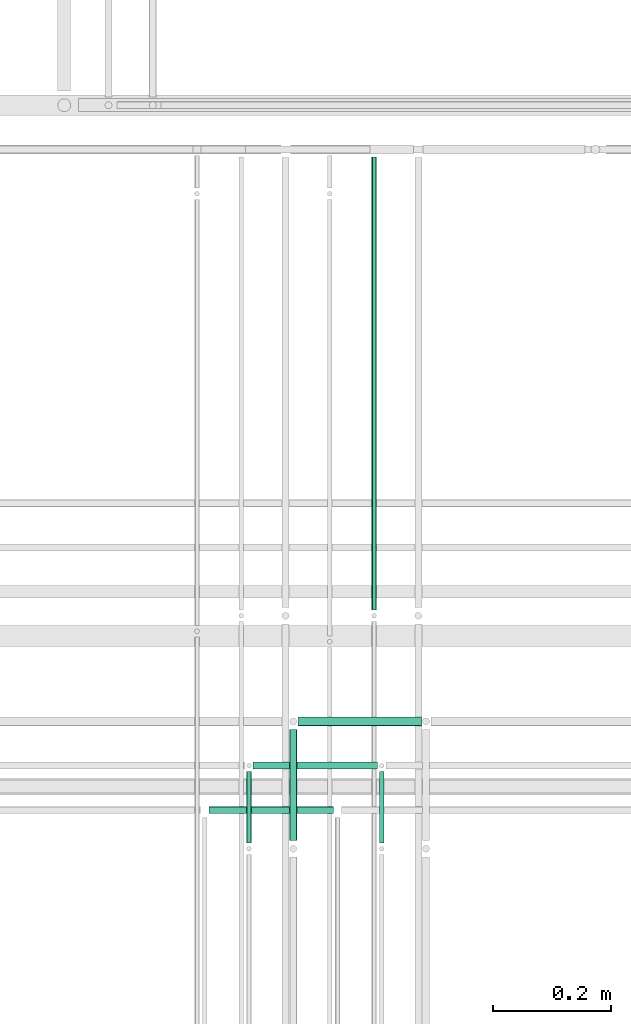
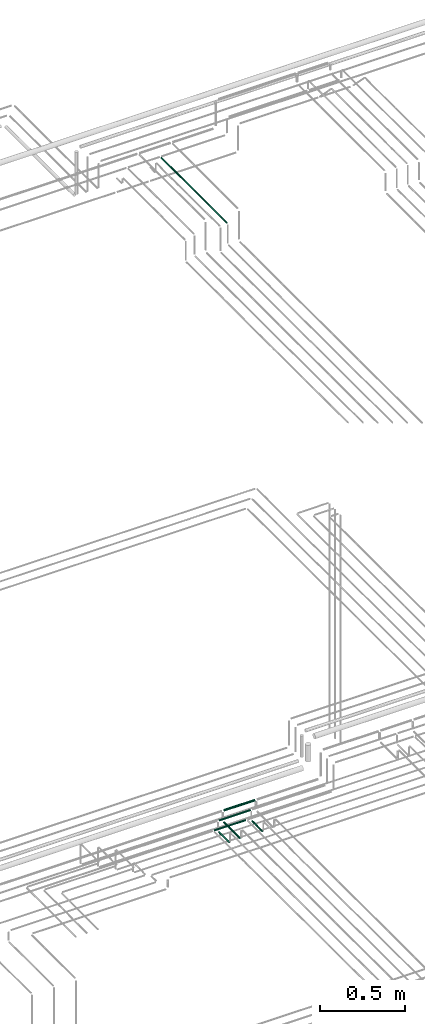
# One storey, part 150 of 331: 7 flow segments.
"""IFC2X3 building model written with IfcOpenShell, lengths in millimetres."""

import ifcopenshell
import ifcopenshell.guid

model = None  # the IFC model being written
_history = None  # IfcOwnerHistory: only IFC2X3 demands one
_inside = {}  # id of a spatial element -> (the spatial element, [elements in it])
_under = {}  # id of a project, library or spatial element -> (it, [spatial elements below it])
_declared = {}  # id of a project -> (the project, [libraries it declares])
_typed = {}  # id of a type object -> (the type object, [elements of that type])
_made_of = {}  # id of a material, layer set ... -> (it, [elements and type objects made of it])


def new_model(schema):
    """Start an empty IFC model of exactly this schema.

    Asked for "IFC4X3", IfcOpenShell would pick the latest addendum, in which some entities
    have other attributes; the version numbers below select the first issue.
    IFC2X3 requires an IfcOwnerHistory on every rooted entity: one is made here for all.
    """
    global model, _history
    if schema == "IFC4X3":
        model = ifcopenshell.file(schema_version=(4, 3, 0, 0))
    else:
        model = ifcopenshell.file(schema=schema)
    _inside.clear()
    _under.clear()
    _declared.clear()
    _typed.clear()
    _made_of.clear()
    _history = None
    if model.schema == "IFC2X3":
        org = make("IfcOrganization", Name="unknown")
        user = make(
            "IfcPersonAndOrganization",
            ThePerson=make("IfcPerson", FamilyName="unknown"),
            TheOrganization=org,
        )
        app = make(
            "IfcApplication",
            ApplicationDeveloper=org,
            Version="unknown",
            ApplicationFullName="unknown",
            ApplicationIdentifier="unknown",
        )
        _history = make(
            "IfcOwnerHistory",
            OwningUser=user,
            OwningApplication=app,
            ChangeAction="ADDED",
            CreationDate=0,
        )
    return model


def make(cls, **values):
    """One entity of the class cls with the attributes given. An attribute that is None is left unset."""
    return model.create_entity(
        cls, **{name: value for name, value in values.items() if value is not None}
    )


def entity(cls, *values):
    """Any entity or typed value of the class cls, its attributes in the order of the schema. None: left unset."""
    e = model.create_entity(cls)
    for i, value in enumerate(values):
        if value is not None:
            e[i] = value
    return e


def rooted(cls, **values):
    """An entity with a GlobalId (a new one), such as an element, a storey or a relation."""
    return make(cls, GlobalId=ifcopenshell.guid.new(), OwnerHistory=_history, **values)


def si_unit(unit_type, name, prefix=None):
    """IfcSIUnit, for example si_unit("LENGTHUNIT", "METRE", prefix="MILLI")."""
    return make("IfcSIUnit", UnitType=unit_type, Prefix=prefix, Name=name)


def converted_unit(unit_type, name, factor, base, dimensions=None, offset=None):
    """IfcConversionBasedUnit, such as the inch: factor (a typed value) times the base unit."""
    return make(
        "IfcConversionBasedUnit"
        if offset is None
        else "IfcConversionBasedUnitWithOffset",
        ConversionOffset=offset,
        Dimensions=None
        if dimensions is None
        else entity("IfcDimensionalExponents", *dimensions),
        UnitType=unit_type,
        Name=name,
        ConversionFactor=make(
            "IfcMeasureWithUnit", ValueComponent=factor, UnitComponent=base
        ),
    )


def derived_unit(unit_type, elements):
    """IfcDerivedUnit: a product of units, each with its exponent."""
    return make(
        "IfcDerivedUnit",
        Elements=[
            make("IfcDerivedUnitElement", Unit=unit, Exponent=power)
            for unit, power in elements
        ],
        UnitType=unit_type,
    )


def assignment(units):
    """IfcUnitAssignment: the units of a project."""
    return None if units is None else make("IfcUnitAssignment", Units=units)


def point(xyz):
    """IfcCartesianPoint."""
    return None if xyz is None else make("IfcCartesianPoint", Coordinates=xyz)


def direction(xyz):
    """IfcDirection."""
    return None if xyz is None else make("IfcDirection", DirectionRatios=xyz)


def frame(location, z_axis=None, x_axis=None):
    """IfcAxis2Placement3D, a coordinate frame: its origin and axes. An axis left out is left unset."""
    return make(
        "IfcAxis2Placement3D",
        Location=point(location),
        Axis=direction(z_axis),
        RefDirection=direction(x_axis),
    )


def frame_2d(location, x_axis=None):
    """IfcAxis2Placement2D, a coordinate frame in the plane: its origin and x axis."""
    return make(
        "IfcAxis2Placement2D", Location=point(location), RefDirection=direction(x_axis)
    )


def origin():
    """The frame at (0, 0, 0) with its axes left unset."""
    return frame((0.0, 0.0, 0.0))


def origin_2d_with_axis():
    """The frame at (0, 0) in the plane with the x axis (1, 0) written out."""
    return frame_2d((0.0, 0.0), x_axis=(1.0, 0.0))


def place(relative_to, where):
    """IfcLocalPlacement: puts the frame where relative to a parent placement (None: the world)."""
    return make(
        "IfcLocalPlacement", PlacementRelTo=relative_to, RelativePlacement=where
    )


def context(
    kind, dimensions, precision=None, world=None, true_north=None, identifier=None
):
    """IfcGeometricRepresentationContext, for example the 3D "Model" context."""
    return make(
        "IfcGeometricRepresentationContext",
        ContextIdentifier=identifier,
        ContextType=kind,
        CoordinateSpaceDimension=dimensions,
        Precision=precision,
        WorldCoordinateSystem=world,
        TrueNorth=true_north,
    )


def subcontext(parent, identifier, kind, view, scale=None):
    """IfcGeometricRepresentationSubContext, for example "Body" below "Model"."""
    return make(
        "IfcGeometricRepresentationSubContext",
        ContextIdentifier=identifier,
        ContextType=kind,
        ParentContext=parent,
        TargetScale=scale,
        TargetView=view,
    )


def project(units=None, contexts=None):
    """IfcProject with its units and contexts."""
    return rooted(
        "IfcProject",
        Name="project",
        RepresentationContexts=contexts,
        UnitsInContext=assignment(units),
    )


def spatial(cls, under=None, at=None, **own):
    """A site, building, storey or space (cls), placed at a placement, below another one or the project."""
    s = rooted(cls, ObjectPlacement=at, **own)
    if under is not None:
        _under.setdefault(under.id(), (under, []))[1].append(s)
    return s


def profile(cls, at=None, kind="AREA", **sizes):
    """A parametric profile (cls). Its sizes go by their IFC names, for example OverallWidth=200.0."""
    return make(cls, ProfileType=kind, Position=at, **sizes)


def circle(**sizes):
    """IfcCircleProfileDef."""
    return profile("IfcCircleProfileDef", **sizes)


def extrude(swept, where, along, depth):
    """IfcExtrudedAreaSolid: the profile swept, set in the frame where, extruded along a direction by depth."""
    return make(
        "IfcExtrudedAreaSolid",
        SweptArea=swept,
        Position=where,
        ExtrudedDirection=direction(along),
        Depth=depth,
    )


def shape(context_of_items, identifier, shape_type, items):
    """IfcShapeRepresentation: the items that make up one representation, for example the "Body"."""
    return make(
        "IfcShapeRepresentation",
        ContextOfItems=context_of_items,
        RepresentationIdentifier=identifier,
        RepresentationType=shape_type,
        Items=items,
    )


def made_of(thing, what):
    """Note that an element or type object is made of a material, layer set ...; save() writes the relation."""
    if what is not None:
        _made_of.setdefault(what.id(), (what, []))[1].append(thing)
    return thing


def type_object(cls, material=None, **own):
    """A type object (cls), such as IfcWallType, which elements share."""
    return made_of(rooted(cls, **own), material)


def element(
    cls,
    number,
    at=None,
    inside=None,
    cuts=None,
    type_object=None,
    material=None,
    context=None,
    identifier="Body",
    shape_type=None,
    held_by="IfcProductDefinitionShape",
    body=None,
    shapes=None,
    **own,
):
    """One element of the class cls, such as IfcWall. Its Tag is "e" and its number.

    at: its placement. inside: the storey or other place that contains it. cuts: it is an
    opening in that element (IfcRelVoidsElement). A single representation is given by context,
    identifier, shape_type and body (its items); several are given by shapes. held_by: the class
    of the entity that holds the representations. save() writes the other relations.
    """
    e = rooted(cls, Tag="e%d" % number, ObjectPlacement=at, **own)
    if body is not None:
        shapes = [shape(context, identifier, shape_type, body)]
    if shapes is not None:
        e.Representation = make(held_by, Representations=shapes)
    if inside is not None:
        _inside.setdefault(inside.id(), (inside, []))[1].append(e)
    if cuts is not None:
        rooted(
            "IfcRelVoidsElement", RelatingBuildingElement=cuts, RelatedOpeningElement=e
        )
    if type_object is not None:
        _typed.setdefault(type_object.id(), (type_object, []))[1].append(e)
    return made_of(e, material)


def aggregate(whole, parts):
    """IfcRelAggregates: a whole, such as a stair, and the parts it consists of."""
    return rooted("IfcRelAggregates", RelatingObject=whole, RelatedObjects=parts)


def save(model, path):
    """Write the relations noted so far, then the file.

    IfcRelAggregates (storeys below a building ...), IfcRelContainedInSpatialStructure (elements
    in a storey), IfcRelDefinesByType, IfcRelAssociatesMaterial and IfcRelDeclares: one each for
    every whole, place, type object, material and project.
    """
    for whole, parts in _under.values():
        aggregate(whole, parts)
    for where, things in _inside.values():
        rooted(
            "IfcRelContainedInSpatialStructure",
            RelatedElements=things,
            RelatingStructure=where,
        )
    for kind, things in _typed.values():
        rooted("IfcRelDefinesByType", RelatedObjects=things, RelatingType=kind)
    for what, things in _made_of.values():
        rooted("IfcRelAssociatesMaterial", RelatedObjects=things, RelatingMaterial=what)
    for by, libraries in _declared.values():
        rooted("IfcRelDeclares", RelatingContext=by, RelatedDefinitions=libraries)
    model.write(path)


model = new_model("IFC2X3")

# Units and contexts
model_context = context("Model", 3, precision=0.01, world=origin(), true_north=direction((6.12303176911189e-17, 1.0)))
body_context = subcontext(model_context, "Body", "Model", "MODEL_VIEW")
ifc_project = project(units=[si_unit("LENGTHUNIT", "METRE", prefix="MILLI"), si_unit("AREAUNIT", "SQUARE_METRE"), si_unit("VOLUMEUNIT", "CUBIC_METRE"), converted_unit("PLANEANGLEUNIT", "DEGREE", entity("IfcRatioMeasure", 0.0174532925199433), si_unit("PLANEANGLEUNIT", "RADIAN"), dimensions=[0, 0, 0, 0, 0, 0, 0]), si_unit("MASSUNIT", "GRAM", prefix="KILO"), derived_unit("MASSDENSITYUNIT", [(si_unit("MASSUNIT", "GRAM", prefix="KILO"), 1), (si_unit("LENGTHUNIT", "METRE"), -3)]), derived_unit("MOMENTOFINERTIAUNIT", [(si_unit("LENGTHUNIT", "METRE"), 4)]), si_unit("TIMEUNIT", "SECOND"), si_unit("FREQUENCYUNIT", "HERTZ"), si_unit("THERMODYNAMICTEMPERATUREUNIT", "DEGREE_CELSIUS"), derived_unit("THERMALTRANSMITTANCEUNIT", [(si_unit("MASSUNIT", "GRAM", prefix="KILO"), 1), (si_unit("THERMODYNAMICTEMPERATUREUNIT", "KELVIN"), -1), (si_unit("TIMEUNIT", "SECOND"), -3)]), derived_unit("VOLUMETRICFLOWRATEUNIT", [(si_unit("LENGTHUNIT", "METRE"), 3), (si_unit("TIMEUNIT", "SECOND"), -1)]), derived_unit("MASSFLOWRATEUNIT", [(si_unit("MASSUNIT", "GRAM", prefix="KILO"), 1), (si_unit("TIMEUNIT", "SECOND"), -1)]), derived_unit("ROTATIONALFREQUENCYUNIT", [(si_unit("TIMEUNIT", "SECOND"), -1)]), si_unit("ELECTRICCURRENTUNIT", "AMPERE"), si_unit("ELECTRICVOLTAGEUNIT", "VOLT"), si_unit("POWERUNIT", "WATT"), si_unit("FORCEUNIT", "NEWTON", prefix="KILO"), si_unit("ILLUMINANCEUNIT", "LUX"), si_unit("LUMINOUSFLUXUNIT", "LUMEN"), si_unit("LUMINOUSINTENSITYUNIT", "CANDELA"), derived_unit("USERDEFINED", [(si_unit("MASSUNIT", "GRAM", prefix="KILO"), -1), (si_unit("LENGTHUNIT", "METRE"), -2), (si_unit("TIMEUNIT", "SECOND"), 3), (si_unit("LUMINOUSFLUXUNIT", "LUMEN"), 1)]), derived_unit("LINEARVELOCITYUNIT", [(si_unit("LENGTHUNIT", "METRE"), 1), (si_unit("TIMEUNIT", "SECOND"), -1)]), si_unit("PRESSUREUNIT", "PASCAL"), derived_unit("USERDEFINED", [(si_unit("LENGTHUNIT", "METRE"), -2), (si_unit("MASSUNIT", "GRAM", prefix="KILO"), 1), (si_unit("TIMEUNIT", "SECOND"), -2)]), derived_unit("LINEARFORCEUNIT", [(si_unit("MASSUNIT", "GRAM", prefix="KILO"), 1), (si_unit("LENGTHUNIT", "METRE"), 1), (si_unit("TIMEUNIT", "SECOND"), -2), (si_unit("LENGTHUNIT", "METRE"), -1)]), derived_unit("PLANARFORCEUNIT", [(si_unit("MASSUNIT", "GRAM", prefix="KILO"), 1), (si_unit("LENGTHUNIT", "METRE"), 1), (si_unit("TIMEUNIT", "SECOND"), -2), (si_unit("LENGTHUNIT", "METRE"), -2)])], contexts=[model_context])

# Site, building, storey
site_placement = place(None, frame((0.0, -0.00077364408347762, 0.0)))
site = spatial("IfcSite", under=ifc_project, at=site_placement, CompositionType="ELEMENT")
building_placement = place(site_placement, origin())
building = spatial("IfcBuilding", under=site, at=building_placement, CompositionType="ELEMENT")
storey_placement = place(building_placement, origin())
storey = spatial("IfcBuildingStorey", under=building, at=storey_placement, CompositionType="ELEMENT", Elevation=0.0)

# Flow segments
pipe_segment_type = type_object("IfcPipeSegmentType", PredefinedType="NOTDEFINED")
flow_segment_1_placement = place(storey_placement, frame((34478.5132627125, 8100.14924977612, 14469.404727873)))
element("IfcFlowSegment", 1, at=flow_segment_1_placement, inside=storey, type_object=pipe_segment_type, context=body_context, shape_type="SweptSolid", body=[
    extrude(circle(Radius=4.0, at=origin_2d_with_axis()), frame((5.59527223591499, 0.0, 5.59527223591499), z_axis=(0.0, 1.0, 0.0), x_axis=(1.0, 0.0, 0.0)), (0.0, 0.0, 1.0), 120.860694073205),
])
flow_segment_2_placement = place(storey_placement, frame((34253.5132627125, 8100.14924977612, 14469.404727873)))
element("IfcFlowSegment", 2, at=flow_segment_2_placement, inside=storey, type_object=pipe_segment_type, context=body_context, shape_type="SweptSolid", body=[
    extrude(circle(Radius=4.0, at=origin_2d_with_axis()), frame((5.59527223591499, 0.0, 5.59527223591499), z_axis=(0.0, 1.0, 0.0), x_axis=(1.0, 0.0, 0.0)), (0.0, 0.0, 1.0), 120.860694073208),
])
flow_segment_3_placement = place(storey_placement, frame((34326.5132627125, 8104.14924977613, 14467.404727873)))
element("IfcFlowSegment", 3, at=flow_segment_3_placement, inside=storey, type_object=pipe_segment_type, context=body_context, shape_type="SweptSolid", body=[
    extrude(circle(Radius=6.0, at=origin_2d_with_axis()), frame((7.59527223591454, 0.0, 7.5952722359167), z_axis=(0.0, 1.0, 0.0), x_axis=(1.0, 0.0, 0.0)), (0.0, 0.0, 1.0), 187.860694073206),
])
flow_segment_4_placement = place(storey_placement, frame((34191.1085349484, 8148.41467161336, 14542.4047277641)))
element("IfcFlowSegment", 4, at=flow_segment_4_placement, inside=storey, type_object=pipe_segment_type, context=body_context, shape_type="SweptSolid", body=[
    extrude(circle(Radius=6.0, at=frame_2d((4.33146851719357e-12, 0.0), x_axis=(1.0, 0.0))), frame((0.0, 7.59527223591995, 7.5952722359167), z_axis=(1.0, 0.0, 0.0), x_axis=(0.0, 1.0, 0.0)), (0.0, 0.0, 1.0), 211.0),
])
flow_segment_5_placement = place(storey_placement, frame((34266.1085388696, 8223.41467161341, 14542.4040467364)))
element("IfcFlowSegment", 5, at=flow_segment_5_placement, inside=storey, type_object=pipe_segment_type, context=body_context, shape_type="SweptSolid", body=[
    extrude(circle(Radius=6.0, at=frame_2d((-2.16573425859679e-12, 2.16573425859679e-12), x_axis=(1.0, 0.0))), frame((0.0, 7.59527223591778, 7.59527223591454), z_axis=(1.0, 0.0, 0.0), x_axis=(0.0, 1.0, 0.0)), (0.0, 0.0, 1.0), 211.0),
])
flow_segment_6_placement = place(storey_placement, frame((34342.1085305349, 8296.91467161341, 14540.9038130214)))
element("IfcFlowSegment", 6, at=flow_segment_6_placement, inside=storey, type_object=pipe_segment_type, context=body_context, shape_type="SweptSolid", body=[
    extrude(circle(Radius=7.5, at=frame_2d((-1.08286712929839e-12, 7.78132442118943e-31), x_axis=(1.0, 0.0))), frame((0.0, 9.09527223591744, 9.09527223591636), z_axis=(1.0, 0.0, 0.0), x_axis=(0.0, 1.0, 0.0)), (0.0, 0.0, 1.0), 209.0),
])
flow_segment_7_placement = place(storey_placement, frame((34465.4558773093, 8494.81073448235, 18594.4047277641)))
element("IfcFlowSegment", 7, at=flow_segment_7_placement, inside=storey, type_object=pipe_segment_type, context=body_context, shape_type="SweptSolid", body=[
    extrude(circle(Radius=4.0, at=origin_2d_with_axis()), frame((5.59527223591499, 0.0, 5.59527223591499), z_axis=(0.0, 1.0, 0.0), x_axis=(1.0, 0.0, 0.0)), (0.0, 0.0, 1.0), 767.18926551793),
])

save(model, "model.ifc")
